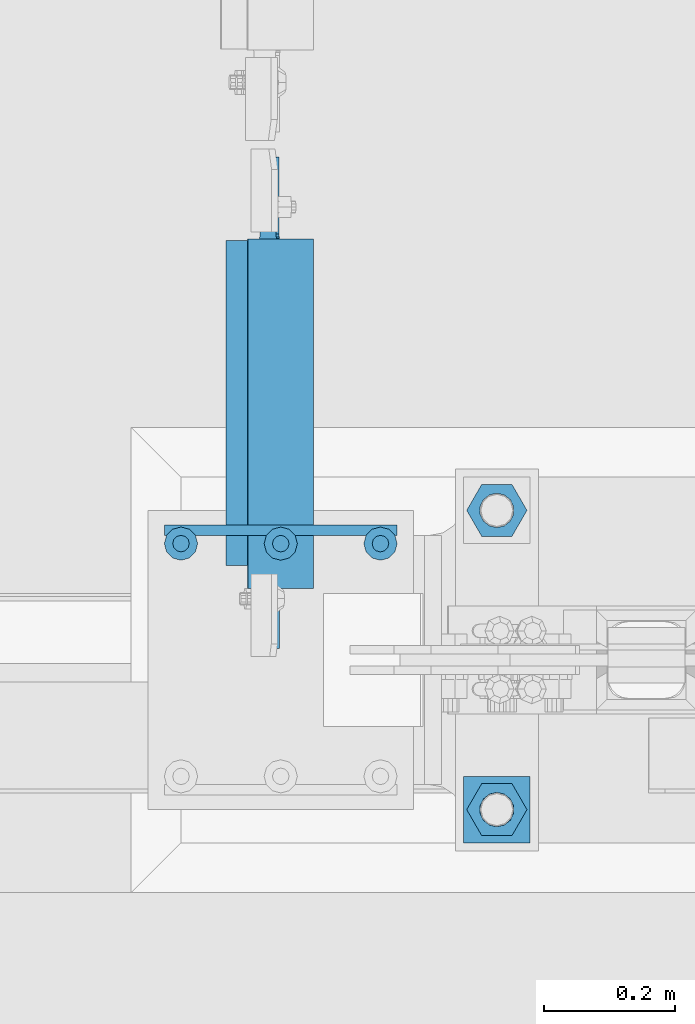
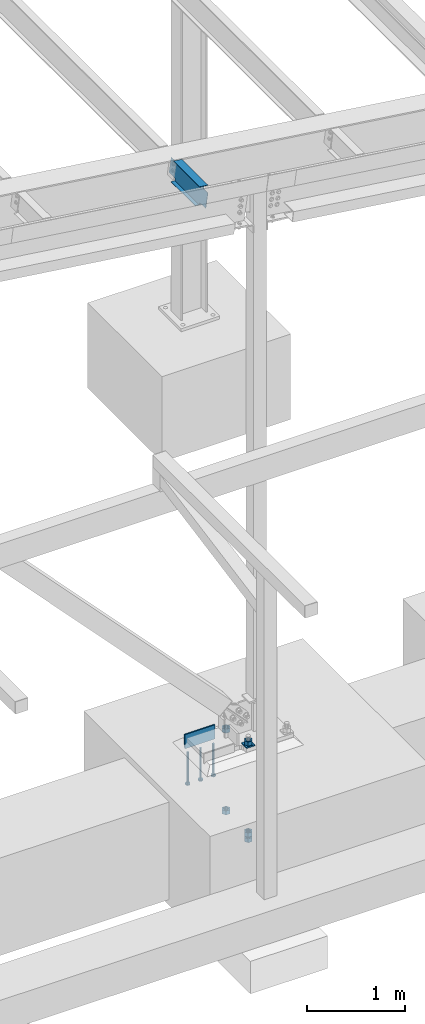
# One storey, part 850 of 1179: 11 beams, 4 elements without a shape of their own.
"""IFC2X3 building model written with IfcOpenShell, lengths in millimetres."""

from ifc_helpers import new_model, si_unit, frame, origin_with_axes, place, context, subcontext, project, spatial, faceted_brep, material, type_object, element, aggregate, save


model = new_model("IFC2X3")

# Units and contexts
model_context = context("Model", 3, precision=1e-05, world=origin_with_axes())
body_context = subcontext(model_context, "Body", "Model", "MODEL_VIEW")
ifc_project = project(units=[si_unit("LENGTHUNIT", "METRE", prefix="MILLI"), si_unit("AREAUNIT", "SQUARE_METRE"), si_unit("VOLUMEUNIT", "CUBIC_METRE"), si_unit("MASSUNIT", "GRAM", prefix="KILO"), si_unit("TIMEUNIT", "SECOND"), si_unit("PLANEANGLEUNIT", "RADIAN"), si_unit("SOLIDANGLEUNIT", "STERADIAN"), si_unit("THERMODYNAMICTEMPERATUREUNIT", "DEGREE_CELSIUS"), si_unit("LUMINOUSINTENSITYUNIT", "LUMEN")], contexts=[model_context])

# Site, building, storey
site_placement = place(None, origin_with_axes())
site = spatial("IfcSite", under=ifc_project, at=site_placement, CompositionType="ELEMENT")
building_placement = place(site_placement, origin_with_axes())
building = spatial("IfcBuilding", under=site, at=building_placement, Name="Undefined", CompositionType="ELEMENT")
storey_placement = place(building_placement, origin_with_axes())
storey = spatial("IfcBuildingStorey", under=building, at=storey_placement, Name="Undefined", CompositionType="ELEMENT", Elevation=0.0)

# Assembly, beam
assembly_1_placement = place(storey_placement, origin_with_axes())
assembly_1 = element("IfcElementAssembly", 1, at=assembly_1_placement, inside=storey, Name="BEAM", AssemblyPlace="NOTDEFINED", PredefinedType="RIGID_FRAME")
ifc_material_1 = material(Name="STEEL/A992")
beam_type_1 = type_object("IfcBeamType", Name="W10X12", PredefinedType="NOTDEFINED")
beam_1_placement = place(assembly_1_placement, frame((34349.418149051, 4648.2, 6554.19004945097), z_axis=(0.133813223953133, 0.0, 0.991006569652931), x_axis=(0.0, 1.0, 0.0)))
beam_1 = element("IfcBeam", 2, at=beam_1_placement, type_object=beam_type_1, material=ifc_material_1, Name="BEAM", ObjectType="W10X12", context=body_context, shape_type="Brep", body=[
    faceted_brep([(641.349999999998, -2.38124999986758, -120.650000000041), (641.349999999998, -50.7999999998792, -120.650000000054), (641.349999999998, -50.7999999998719, -125.412500000057), (641.349999999998, 50.8000000001484, -125.412500000028), (641.349999999998, 50.8000000001412, -120.650000000027), (641.349999999998, 2.38125000012951, -120.650000000038), (641.349999999998, 2.38125000012224, -106.362499801333), (641.349999999998, -2.38124999988213, -106.362499801329), (642.316729922585, 2.38125000011496, -101.502420283283), (642.316729922585, -2.38124999988213, -101.502420283279), (645.069743823064, 2.38125000011496, -97.3822438151255), (645.069743823064, -2.38124999988941, -97.3822438151219), (649.189920291217, 2.38125000010768, -94.6292299146444), (649.189920291217, -2.38124999989668, -94.6292299146407), (654.049999809263, 2.38125000010768, -93.6624999920532), (654.049999809263, -2.38124999989668, -93.6624999920496), (768.349999999998, -2.38124999988941, -93.6624999919513), (768.349999999998, 2.38125000010768, -93.6624999919441), (109.537500000001, 2.38124999985303, 120.650000000041), (109.537500000001, 50.7999999998647, 120.650000000056), (642.937499999997, 50.7999999998647, 120.650000000056), (642.937499999997, 2.38124999985303, 120.650000000041), (144.462500000001, -2.38124999988213, -106.362499807816), (144.462500000001, 2.38125000011496, -106.362499807819), (144.462500000001, 2.38125000012951, -120.650000000038), (144.462500000001, 50.8000000001412, -120.650000000027), (144.462500000001, 50.8000000001484, -125.412500000028), (144.462500000001, -50.7999999998719, -125.412500000057), (144.462500000001, -50.7999999998792, -120.650000000054), (144.462500000001, -2.38124999986758, -120.650000000041), (143.495770077414, -2.38124999988213, -101.502420289766), (143.495770077414, 2.38125000011496, -101.502420289768), (140.742756176935, -2.38124999988941, -97.3822438216066), (140.742756176935, 2.38125000011496, -97.3822438216102), (136.622579708782, -2.38124999989668, -94.6292299211254), (136.622579708782, 2.38125000010768, -94.6292299211291), (131.762500190736, -2.38124999988941, -93.6624999985379), (131.762500190736, 2.38125000010768, -93.6624999985397), (17.4624999999996, -2.38124999988941, -93.662499998647), (17.4624999999996, 2.38125000010768, -93.6624999986416), (17.4624999999996, -2.38125000011496, 93.6625000015429), (17.4624999999996, 2.38124999988941, 93.6625000015483), (96.8375001907361, -2.38125000011496, 93.662500001652), (96.8375001907361, 2.38124999988941, 93.6625000016502), (101.697579708782, -2.38125000011496, 94.6292299242414), (101.697579708782, 2.38124999987485, 94.6292299242377), (105.817756176935, -2.38125000011496, 97.3822438247225), (105.817756176935, 2.38124999988213, 97.3822438247189), (108.570770077414, -2.38125000012224, 101.50242029288), (108.570770077414, 2.38124999987485, 101.502420292876), (109.537500000001, -2.38125000012951, 106.36249981093), (109.537500000001, 2.38124999986758, 106.362499810928), (109.537500000001, -50.800000000163, 125.412500000028), (109.537500000001, 50.7999999998574, 125.412500000059), (109.537500000001, -2.38125000014406, 120.650000000041), (109.537500000001, -50.8000000001557, 120.650000000027), (642.937499999997, -2.38125000014406, 120.650000000041), (642.937499999997, -50.8000000001557, 120.650000000027), (642.937499999997, -50.800000000163, 125.412500000028), (642.937499999997, 50.7999999998574, 125.412500000059), (642.937499999997, -2.38125000012224, 100.012499817411), (642.937499999997, 2.38124999987485, 100.012499817409), (643.904229922585, -2.38125000012224, 95.1524202993623), (643.904229922585, 2.38124999988213, 95.1524202993587), (646.657243823063, -2.38125000011496, 91.0322438312032), (646.657243823063, 2.38124999988941, 91.0322438311996), (650.777420291217, -2.38125000010768, 88.2792299307239), (650.777420291217, 2.38124999988941, 88.2792299307202), (655.637499809262, -2.38125000010768, 87.3125000081345), (655.637499809262, 2.38124999988941, 87.3125000081309), (768.349999999998, -2.38125000010768, 87.3125000082346), (768.349999999998, 2.38124999988941, 87.31250000824)], [[[0, 1, 2, 3, 4, 5, 6, 7]], [[7, 6, 8, 9]], [[9, 8, 10, 11]], [[11, 10, 12, 13]], [[13, 12, 14, 15]], [[16, 15, 14, 17]], [[18, 19, 20, 21]], [[22, 23, 24, 25, 26, 27, 28, 29]], [[30, 31, 23, 22]], [[32, 33, 31, 30]], [[34, 35, 33, 32]], [[36, 37, 35, 34]], [[38, 39, 37, 36]], [[40, 41, 39, 38]], [[42, 43, 41, 40]], [[44, 45, 43, 42]], [[46, 47, 45, 44]], [[48, 49, 47, 46]], [[50, 51, 49, 48]], [[52, 53, 19, 18, 51, 50, 54, 55]], [[55, 54, 56, 57]], [[52, 55, 57, 58]], [[53, 52, 58, 59]], [[19, 53, 59, 20]], [[58, 57, 56, 60, 61, 21, 20, 59]], [[62, 63, 61, 60]], [[64, 65, 63, 62]], [[66, 67, 65, 64]], [[68, 69, 67, 66]], [[70, 71, 69, 68]], [[71, 70, 16, 17]], [[12, 10, 8, 6, 5, 24, 23, 31, 33, 35, 37, 39, 41, 43, 45, 47, 49, 51, 18, 21, 61, 63, 65, 67, 69, 71, 17, 14]], [[25, 24, 5, 4]], [[26, 25, 4, 3]], [[27, 26, 3, 2]], [[28, 27, 2, 1]], [[29, 28, 1, 0]], [[70, 68, 66, 64, 62, 60, 56, 54, 50, 48, 46, 44, 42, 40, 38, 36, 34, 32, 30, 22, 29, 0, 7, 9, 11, 13, 15, 16]]]),
])
aggregate(assembly_1, [beam_1])

# Assembly, beams
assembly_2_placement = place(storey_placement, origin_with_axes())
assembly_2 = element("IfcElementAssembly", 3, at=assembly_2_placement, inside=storey, Name="TEMPLATE", AssemblyPlace="NOTDEFINED", PredefinedType="RIGID_FRAME")
ifc_material_2 = material(Name="STEEL/A36")
beam_type_2 = type_object("IfcBeamType", PredefinedType="NOTDEFINED")
beam_2_placement = place(assembly_2_placement, frame((34747.1989938965, 4419.60000610352, -220.662499999998), z_axis=(0.0, -1.0, 0.0), x_axis=(-1.0, 0.0, 0.0)))
beam_2 = element("IfcBeam", 4, at=beam_2_placement, type_object=beam_type_2, material=ifc_material_2, Name="SQ WASHER", context=body_context, shape_type="Brep", body=[
    faceted_brep([(0.0, 7.9375, -50.8000000000002), (0.0, 7.9375, 50.8000000000002), (101.598992919513, 7.9375, 50.8000000000002), (101.598992919513, 7.9375, -50.8000000000002), (0.0, -7.9375, 50.8000000000002), (101.598992919513, -7.9375, 50.8000000000002), (0.0, -7.9375, -50.8000000000002), (101.598992919513, -7.9375, -50.8000000000002)], [[[0, 1, 2, 3]], [[1, 4, 5, 2]], [[4, 6, 7, 5]], [[6, 0, 3, 7]], [[5, 7, 3, 2]], [[6, 4, 1, 0]]]),
])
beam_type_3 = type_object("IfcBeamType", Name="2_HEAVY_HEX_NUT", PredefinedType="NOTDEFINED")
beam_3_placement = place(assembly_2_placement, frame((34696.400012207, 4876.8, -279.4), z_axis=(0.0, -1.0, 0.0), x_axis=(0.0, 0.0, -1.0)))
beam_3 = element("IfcBeam", 5, at=beam_3_placement, type_object=beam_type_3, material=ifc_material_2, Name="NUT", ObjectType="2_HEAVY_HEX_NUT", context=body_context, shape_type="Brep", body=[
    faceted_brep([(0.0, -46.0369987487793, 9.09494701772928e-13), (0.0, -23.0184993743896, -39.869213104248), (50.7999999999993, -23.0184993743896, -39.869213104248), (50.7999999999993, -46.0369987487793, 9.09494701772928e-13), (0.0, 23.0184993743896, -39.869213104248), (50.7999999999993, 23.0184993743896, -39.869213104248), (0.0, 46.0369987487793, -9.09494701772928e-13), (50.7999999999993, 46.0369987487793, -9.09494701772928e-13), (0.0, 23.0184993743896, 39.869213104248), (50.7999999999993, 23.0184993743896, 39.869213104248), (0.0, -23.0184993743896, 39.869213104248), (50.7999999999993, -23.0184993743896, 39.869213104248), (0.0, 0.0, 26.1940002441406), (0.0, 11.3650617044477, 23.5999013092769), (50.7999999999993, 11.3650617044477, 23.5999013092769), (50.7999999999993, 0.0, 26.1940002441406), (0.0, 20.4791109456419, 16.3316083006703), (50.7999999999993, 20.4791109456419, 16.3316083006703), (0.0, 25.5370200498364, 5.82867859874477), (50.7999999999993, 25.5370200498364, 5.82867859874477), (0.0, 25.5370200498364, -5.82867859874477), (50.7999999999993, 25.5370200498364, -5.82867859874477), (0.0, 20.4791109456419, -16.3316083006703), (50.7999999999993, 20.4791109456419, -16.3316083006703), (0.0, 11.365061704455, -23.5999013092769), (50.7999999999993, 11.365061704455, -23.5999013092769), (0.0, 0.0, -26.1940002441406), (50.7999999999993, 0.0, -26.1940002441406), (0.0, -11.3650617044477, -23.5999013092769), (50.7999999999993, -11.3650617044477, -23.5999013092769), (0.0, -20.4791109456419, -16.3316083006703), (50.7999999999993, -20.4791109456419, -16.3316083006703), (0.0, -25.5370200498364, -5.82867859874477), (50.7999999999993, -25.5370200498364, -5.82867859874477), (0.0, -25.5370200498364, 5.82867859874477), (50.7999999999993, -25.5370200498364, 5.82867859874477), (0.0, -20.4791109456419, 16.3316083006703), (50.7999999999993, -20.4791109456419, 16.3316083006703), (0.0, -11.365061704455, 23.5999013092769), (50.7999999999993, -11.365061704455, 23.5999013092769)], [[[0, 1, 2, 3]], [[1, 4, 5, 2]], [[4, 6, 7, 5]], [[6, 8, 9, 7]], [[8, 10, 11, 9]], [[10, 0, 3, 11]], [[12, 13, 14, 15]], [[13, 16, 17, 14]], [[16, 18, 19, 17]], [[18, 20, 21, 19]], [[20, 22, 23, 21]], [[22, 24, 25, 23]], [[24, 26, 27, 25]], [[26, 28, 29, 27]], [[28, 30, 31, 29]], [[30, 32, 33, 31]], [[32, 34, 35, 33]], [[34, 36, 37, 35]], [[36, 38, 39, 37]], [[38, 12, 15, 39]], [[5, 7, 9, 11, 3, 2], [17, 19, 21, 23, 25, 27, 29, 31, 33, 35, 37, 39, 15, 14]], [[10, 8, 6, 4, 1, 0], [38, 36, 34, 32, 30, 28, 26, 24, 22, 20, 18, 16, 13, 12]]]),
])
beam_4_placement = place(assembly_2_placement, frame((34696.4, 4876.8, -1301.75), z_axis=(0.0, -1.0, 0.0), x_axis=(0.0, 0.0, -1.0)))
beam_4 = element("IfcBeam", 6, at=beam_4_placement, type_object=beam_type_3, material=ifc_material_2, Name="NUT", ObjectType="2_HEAVY_HEX_NUT", context=body_context, shape_type="Brep", body=[
    faceted_brep([(0.0, -46.0369987487793, 9.09494701772928e-13), (0.0, -23.0184993743896, -39.869213104248), (50.7999999999993, -23.0184993743896, -39.869213104248), (50.7999999999993, -46.0369987487793, 9.09494701772928e-13), (0.0, 23.0184993743896, -39.869213104248), (50.7999999999993, 23.0184993743896, -39.869213104248), (0.0, 46.0369987487793, -9.09494701772928e-13), (50.7999999999993, 46.0369987487793, -9.09494701772928e-13), (0.0, 23.0184993743896, 39.869213104248), (50.7999999999993, 23.0184993743896, 39.869213104248), (0.0, -23.0184993743896, 39.869213104248), (50.7999999999993, -23.0184993743896, 39.869213104248), (0.0, 0.0, 26.1940002441406), (0.0, 11.3650617044477, 23.5999013092769), (50.7999999999993, 11.3650617044477, 23.5999013092769), (50.7999999999993, 0.0, 26.1940002441406), (0.0, 20.4791109456419, 16.3316083006703), (50.7999999999993, 20.4791109456419, 16.3316083006703), (0.0, 25.5370200498364, 5.82867859874477), (50.7999999999993, 25.5370200498364, 5.82867859874477), (0.0, 25.5370200498364, -5.82867859874477), (50.7999999999993, 25.5370200498364, -5.82867859874477), (0.0, 20.4791109456419, -16.3316083006703), (50.7999999999993, 20.4791109456419, -16.3316083006703), (0.0, 11.365061704455, -23.5999013092769), (50.7999999999993, 11.365061704455, -23.5999013092769), (0.0, 0.0, -26.1940002441406), (50.7999999999993, 0.0, -26.1940002441406), (0.0, -11.3650617044477, -23.5999013092769), (50.7999999999993, -11.3650617044477, -23.5999013092769), (0.0, -20.4791109456419, -16.3316083006703), (50.7999999999993, -20.4791109456419, -16.3316083006703), (0.0, -25.5370200498364, -5.82867859874477), (50.7999999999993, -25.5370200498364, -5.82867859874477), (0.0, -25.5370200498364, 5.82867859874477), (50.7999999999993, -25.5370200498364, 5.82867859874477), (0.0, -20.4791109456419, 16.3316083006703), (50.7999999999993, -20.4791109456419, 16.3316083006703), (0.0, -11.365061704455, 23.5999013092769), (50.7999999999993, -11.365061704455, 23.5999013092769)], [[[0, 1, 2, 3]], [[1, 4, 5, 2]], [[4, 6, 7, 5]], [[6, 8, 9, 7]], [[8, 10, 11, 9]], [[10, 0, 3, 11]], [[12, 13, 14, 15]], [[13, 16, 17, 14]], [[16, 18, 19, 17]], [[18, 20, 21, 19]], [[20, 22, 23, 21]], [[22, 24, 25, 23]], [[24, 26, 27, 25]], [[26, 28, 29, 27]], [[28, 30, 31, 29]], [[30, 32, 33, 31]], [[32, 34, 35, 33]], [[34, 36, 37, 35]], [[36, 38, 39, 37]], [[38, 12, 15, 39]], [[5, 7, 9, 11, 3, 2], [17, 19, 21, 23, 25, 27, 29, 31, 33, 35, 37, 39, 15, 14]], [[10, 8, 6, 4, 1, 0], [38, 36, 34, 32, 30, 28, 26, 24, 22, 20, 18, 16, 13, 12]]]),
])
beam_5_placement = place(assembly_2_placement, frame((34696.4, 4419.6, -1301.75), z_axis=(0.0, -1.0, 0.0), x_axis=(0.0, 0.0, -1.0)))
beam_5 = element("IfcBeam", 7, at=beam_5_placement, type_object=beam_type_3, material=ifc_material_2, Name="NUT", ObjectType="2_HEAVY_HEX_NUT", context=body_context, shape_type="Brep", body=[
    faceted_brep([(0.0, -46.0369987487793, 9.09494701772928e-13), (0.0, -23.0184993743896, -39.869213104248), (50.7999999999993, -23.0184993743896, -39.869213104248), (50.7999999999993, -46.0369987487793, 9.09494701772928e-13), (0.0, 23.0184993743896, -39.869213104248), (50.7999999999993, 23.0184993743896, -39.869213104248), (0.0, 46.0369987487793, -9.09494701772928e-13), (50.7999999999993, 46.0369987487793, -9.09494701772928e-13), (0.0, 23.0184993743896, 39.869213104248), (50.7999999999993, 23.0184993743896, 39.869213104248), (0.0, -23.0184993743896, 39.869213104248), (50.7999999999993, -23.0184993743896, 39.869213104248), (0.0, 0.0, 26.1940002441406), (0.0, 11.3650617044477, 23.5999013092769), (50.7999999999993, 11.3650617044477, 23.5999013092769), (50.7999999999993, 0.0, 26.1940002441406), (0.0, 20.4791109456419, 16.3316083006703), (50.7999999999993, 20.4791109456419, 16.3316083006703), (0.0, 25.5370200498364, 5.82867859874477), (50.7999999999993, 25.5370200498364, 5.82867859874477), (0.0, 25.5370200498364, -5.82867859874477), (50.7999999999993, 25.5370200498364, -5.82867859874477), (0.0, 20.4791109456419, -16.3316083006703), (50.7999999999993, 20.4791109456419, -16.3316083006703), (0.0, 11.365061704455, -23.5999013092769), (50.7999999999993, 11.365061704455, -23.5999013092769), (0.0, 0.0, -26.1940002441406), (50.7999999999993, 0.0, -26.1940002441406), (0.0, -11.3650617044477, -23.5999013092769), (50.7999999999993, -11.3650617044477, -23.5999013092769), (0.0, -20.4791109456419, -16.3316083006703), (50.7999999999993, -20.4791109456419, -16.3316083006703), (0.0, -25.5370200498364, -5.82867859874477), (50.7999999999993, -25.5370200498364, -5.82867859874477), (0.0, -25.5370200498364, 5.82867859874477), (50.7999999999993, -25.5370200498364, 5.82867859874477), (0.0, -20.4791109456419, 16.3316083006703), (50.7999999999993, -20.4791109456419, 16.3316083006703), (0.0, -11.365061704455, 23.5999013092769), (50.7999999999993, -11.365061704455, 23.5999013092769)], [[[0, 1, 2, 3]], [[1, 4, 5, 2]], [[4, 6, 7, 5]], [[6, 8, 9, 7]], [[8, 10, 11, 9]], [[10, 0, 3, 11]], [[12, 13, 14, 15]], [[13, 16, 17, 14]], [[16, 18, 19, 17]], [[18, 20, 21, 19]], [[20, 22, 23, 21]], [[22, 24, 25, 23]], [[24, 26, 27, 25]], [[26, 28, 29, 27]], [[28, 30, 31, 29]], [[30, 32, 33, 31]], [[32, 34, 35, 33]], [[34, 36, 37, 35]], [[36, 38, 39, 37]], [[38, 12, 15, 39]], [[5, 7, 9, 11, 3, 2], [17, 19, 21, 23, 25, 27, 29, 31, 33, 35, 37, 39, 15, 14]], [[10, 8, 6, 4, 1, 0], [38, 36, 34, 32, 30, 28, 26, 24, 22, 20, 18, 16, 13, 12]]]),
])
beam_6_placement = place(assembly_2_placement, frame((34696.4, 4419.6, -1371.59999923706), z_axis=(0.0, -1.0, 0.0), x_axis=(0.0, 0.0, -1.0)))
beam_6 = element("IfcBeam", 8, at=beam_6_placement, type_object=beam_type_3, material=ifc_material_2, Name="NUT", ObjectType="2_HEAVY_HEX_NUT", context=body_context, shape_type="Brep", body=[
    faceted_brep([(0.0, -46.0369987487793, 9.09494701772928e-13), (0.0, -23.0184993743896, -39.869213104248), (50.7999999999993, -23.0184993743896, -39.869213104248), (50.7999999999993, -46.0369987487793, 9.09494701772928e-13), (0.0, 23.0184993743896, -39.869213104248), (50.7999999999993, 23.0184993743896, -39.869213104248), (0.0, 46.0369987487793, -9.09494701772928e-13), (50.7999999999993, 46.0369987487793, -9.09494701772928e-13), (0.0, 23.0184993743896, 39.869213104248), (50.7999999999993, 23.0184993743896, 39.869213104248), (0.0, -23.0184993743896, 39.869213104248), (50.7999999999993, -23.0184993743896, 39.869213104248), (0.0, 0.0, 26.1940002441406), (0.0, 11.3650617044477, 23.5999013092769), (50.7999999999993, 11.3650617044477, 23.5999013092769), (50.7999999999993, 0.0, 26.1940002441406), (0.0, 20.4791109456419, 16.3316083006703), (50.7999999999993, 20.4791109456419, 16.3316083006703), (0.0, 25.5370200498364, 5.82867859874477), (50.7999999999993, 25.5370200498364, 5.82867859874477), (0.0, 25.5370200498364, -5.82867859874477), (50.7999999999993, 25.5370200498364, -5.82867859874477), (0.0, 20.4791109456419, -16.3316083006703), (50.7999999999993, 20.4791109456419, -16.3316083006703), (0.0, 11.365061704455, -23.5999013092769), (50.7999999999993, 11.365061704455, -23.5999013092769), (0.0, 0.0, -26.1940002441406), (50.7999999999993, 0.0, -26.1940002441406), (0.0, -11.3650617044477, -23.5999013092769), (50.7999999999993, -11.3650617044477, -23.5999013092769), (0.0, -20.4791109456419, -16.3316083006703), (50.7999999999993, -20.4791109456419, -16.3316083006703), (0.0, -25.5370200498364, -5.82867859874477), (50.7999999999993, -25.5370200498364, -5.82867859874477), (0.0, -25.5370200498364, 5.82867859874477), (50.7999999999993, -25.5370200498364, 5.82867859874477), (0.0, -20.4791109456419, 16.3316083006703), (50.7999999999993, -20.4791109456419, 16.3316083006703), (0.0, -11.365061704455, 23.5999013092769), (50.7999999999993, -11.365061704455, 23.5999013092769)], [[[0, 1, 2, 3]], [[1, 4, 5, 2]], [[4, 6, 7, 5]], [[6, 8, 9, 7]], [[8, 10, 11, 9]], [[10, 0, 3, 11]], [[12, 13, 14, 15]], [[13, 16, 17, 14]], [[16, 18, 19, 17]], [[18, 20, 21, 19]], [[20, 22, 23, 21]], [[22, 24, 25, 23]], [[24, 26, 27, 25]], [[26, 28, 29, 27]], [[28, 30, 31, 29]], [[30, 32, 33, 31]], [[32, 34, 35, 33]], [[34, 36, 37, 35]], [[36, 38, 39, 37]], [[38, 12, 15, 39]], [[5, 7, 9, 11, 3, 2], [17, 19, 21, 23, 25, 27, 29, 31, 33, 35, 37, 39, 15, 14]], [[10, 8, 6, 4, 1, 0], [38, 36, 34, 32, 30, 28, 26, 24, 22, 20, 18, 16, 13, 12]]]),
])
beam_7_placement = place(assembly_2_placement, frame((34696.4, 4419.6, -161.924999999999), z_axis=(0.0, -1.0, 0.0), x_axis=(0.0, 0.0, -1.0)))
beam_7 = element("IfcBeam", 9, at=beam_7_placement, type_object=beam_type_3, material=ifc_material_2, Name="NUT", ObjectType="2_HEAVY_HEX_NUT", context=body_context, shape_type="Brep", body=[
    faceted_brep([(0.0, -46.0369987487793, 9.09494701772928e-13), (0.0, -23.0184993743896, -39.869213104248), (50.7999999999993, -23.0184993743896, -39.869213104248), (50.7999999999993, -46.0369987487793, 9.09494701772928e-13), (0.0, 23.0184993743896, -39.869213104248), (50.7999999999993, 23.0184993743896, -39.869213104248), (0.0, 46.0369987487793, -9.09494701772928e-13), (50.7999999999993, 46.0369987487793, -9.09494701772928e-13), (0.0, 23.0184993743896, 39.869213104248), (50.7999999999993, 23.0184993743896, 39.869213104248), (0.0, -23.0184993743896, 39.869213104248), (50.7999999999993, -23.0184993743896, 39.869213104248), (0.0, 0.0, 26.1940002441406), (0.0, 11.3650617044477, 23.5999013092769), (50.7999999999993, 11.3650617044477, 23.5999013092769), (50.7999999999993, 0.0, 26.1940002441406), (0.0, 20.4791109456419, 16.3316083006703), (50.7999999999993, 20.4791109456419, 16.3316083006703), (0.0, 25.5370200498364, 5.82867859874477), (50.7999999999993, 25.5370200498364, 5.82867859874477), (0.0, 25.5370200498364, -5.82867859874477), (50.7999999999993, 25.5370200498364, -5.82867859874477), (0.0, 20.4791109456419, -16.3316083006703), (50.7999999999993, 20.4791109456419, -16.3316083006703), (0.0, 11.365061704455, -23.5999013092769), (50.7999999999993, 11.365061704455, -23.5999013092769), (0.0, 0.0, -26.1940002441406), (50.7999999999993, 0.0, -26.1940002441406), (0.0, -11.3650617044477, -23.5999013092769), (50.7999999999993, -11.3650617044477, -23.5999013092769), (0.0, -20.4791109456419, -16.3316083006703), (50.7999999999993, -20.4791109456419, -16.3316083006703), (0.0, -25.5370200498364, -5.82867859874477), (50.7999999999993, -25.5370200498364, -5.82867859874477), (0.0, -25.5370200498364, 5.82867859874477), (50.7999999999993, -25.5370200498364, 5.82867859874477), (0.0, -20.4791109456419, 16.3316083006703), (50.7999999999993, -20.4791109456419, 16.3316083006703), (0.0, -11.365061704455, 23.5999013092769), (50.7999999999993, -11.365061704455, 23.5999013092769)], [[[0, 1, 2, 3]], [[1, 4, 5, 2]], [[4, 6, 7, 5]], [[6, 8, 9, 7]], [[8, 10, 11, 9]], [[10, 0, 3, 11]], [[12, 13, 14, 15]], [[13, 16, 17, 14]], [[16, 18, 19, 17]], [[18, 20, 21, 19]], [[20, 22, 23, 21]], [[22, 24, 25, 23]], [[24, 26, 27, 25]], [[26, 28, 29, 27]], [[28, 30, 31, 29]], [[30, 32, 33, 31]], [[32, 34, 35, 33]], [[34, 36, 37, 35]], [[36, 38, 39, 37]], [[38, 12, 15, 39]], [[5, 7, 9, 11, 3, 2], [17, 19, 21, 23, 25, 27, 29, 31, 33, 35, 37, 39, 15, 14]], [[10, 8, 6, 4, 1, 0], [38, 36, 34, 32, 30, 28, 26, 24, 22, 20, 18, 16, 13, 12]]]),
])
aggregate(assembly_2, [beam_3, beam_4, beam_5, beam_6, beam_2, beam_7])

# Assembly, beam
assembly_3_placement = place(storey_placement, origin_with_axes())
assembly_3 = element("IfcElementAssembly", 10, at=assembly_3_placement, inside=storey, Name="PLATE", AssemblyPlace="NOTDEFINED", PredefinedType="RIGID_FRAME")
ifc_material_3 = material(Name="STEEL/A572-GR.50")
beam_type_4 = type_object("IfcBeamType", PredefinedType="NOTDEFINED")
beam_8_placement = place(assembly_3_placement, frame((34543.9999993009, 4846.63750152631, -266.7), z_axis=(0.0, 0.0, 1.0), x_axis=(-1.0, 0.0, 0.0)))
beam_8 = element("IfcBeam", 11, at=beam_8_placement, type_object=beam_type_4, material=ifc_material_3, Name="PLATE", context=body_context, shape_type="Brep", body=[
    faceted_brep([(355.599999999999, 7.9375, -88.9), (355.599999999999, -7.9375, -73.025), (0.0, -7.9375, -73.025), (0.0, 7.9375, -88.9), (0.0, 7.9375, 88.9), (355.599999999999, 7.9375, 88.9), (0.0, -7.9375, 88.9), (355.599999999999, -7.9375, 88.9)], [[[0, 1, 2, 3]], [[3, 4, 5, 0]], [[4, 6, 7, 5]], [[7, 6, 2, 1]], [[5, 7, 1, 0]], [[6, 4, 3, 2]]]),
])
aggregate(assembly_3, [beam_8])

# Assembly, beams
assembly_4_placement = place(storey_placement, origin_with_axes())
assembly_4 = element("IfcElementAssembly", 12, at=assembly_4_placement, inside=storey, Name="EMBED_PLATE", AssemblyPlace="NOTDEFINED", PredefinedType="RIGID_FRAME")
ifc_material_4 = material(Name="STEEL/A108")
beam_type_5 = type_object("IfcBeamType", Name="STUD_1-DIA", PredefinedType="NOTDEFINED")
beam_9_placement = place(assembly_4_placement, frame((34518.6, 4826.0, -393.7), z_axis=(-1.0, 0.0, 0.0), x_axis=(0.0, 0.0, -1.0)))
beam_9 = element("IfcBeam", 13, at=beam_9_placement, type_object=beam_type_5, material=ifc_material_4, Name="STUD", ObjectType="STUD_1-DIA", context=body_context, shape_type="Brep", body=[
    faceted_brep([(0.0, -12.7, 0.0), (0.0, -11.0, -6.34999990463257), (382.016, -11.0, -6.34999990463257), (382.016, -12.6999998092651, 0.0), (0.0, -6.34999990463257, -11.0), (382.016, -6.34999990463257, -11.0), (0.0, 0.0, -12.6999998092651), (382.016, 0.0, -12.6999998092651), (0.0, 6.34999990463257, -11.0), (382.016, 6.34999990463257, -11.0), (0.0, 11.0, -6.34999990463257), (382.016, 11.0, -6.34999990463257), (0.0, 12.7, 0.0), (382.016, 12.6999998092651, 0.0), (0.0, 11.0, 6.34999990463257), (382.016, 11.0, 6.34999990463257), (0.0, 6.34999990463257, 11.0), (382.016, 6.34999990463257, 11.0), (0.0, 0.0, 12.6999998092651), (382.016, 0.0, 12.6999998092651), (0.0, -6.34999990463257, 11.0), (382.016, -6.34999990463257, 11.0), (0.0, -11.0, 6.34999990463257), (382.016, -11.0, 6.34999990463257), (386.08, -22.0, -12.6999998092651), (386.08, -25.3999996185303, 0.0), (386.08, -12.6999998092651, -22.0), (386.08, 0.0, -25.3999996185303), (386.08, 12.6999998092651, -22.0), (386.08, 22.0, -12.6999998092651), (386.08, 25.3999996185303, 0.0), (386.08, 22.0, 12.6999998092651), (386.08, 12.6999998092651, 22.0), (386.08, 0.0, 25.3999996185303), (386.08, -12.6999998092651, 22.0), (386.08, -22.0, 12.6999998092651), (406.4, -22.0, -12.6999998092651), (406.4, -25.3999996185303, 0.0), (406.4, -12.6999998092651, -22.0), (406.4, 0.0, -25.3999996185303), (406.4, 12.6999998092651, -22.0), (406.4, 22.0, -12.6999998092651), (406.4, 25.3999996185303, 0.0), (406.4, 22.0, 12.6999998092651), (406.4, 12.6999998092651, 22.0), (406.4, 0.0, 25.3999996185303), (406.4, -12.6999998092651, 22.0), (406.4, -22.0, 12.6999998092651)], [[[0, 1, 2, 3]], [[1, 4, 5, 2]], [[4, 6, 7, 5]], [[6, 8, 9, 7]], [[8, 10, 11, 9]], [[10, 12, 13, 11]], [[12, 14, 15, 13]], [[14, 16, 17, 15]], [[16, 18, 19, 17]], [[18, 20, 21, 19]], [[20, 22, 23, 21]], [[22, 0, 3, 23]], [[22, 20, 18, 16, 14, 12, 10, 8, 6, 4, 1, 0]], [[3, 2, 24, 25]], [[2, 5, 26, 24]], [[5, 7, 27, 26]], [[7, 9, 28, 27]], [[9, 11, 29, 28]], [[11, 13, 30, 29]], [[13, 15, 31, 30]], [[15, 17, 32, 31]], [[17, 19, 33, 32]], [[19, 21, 34, 33]], [[21, 23, 35, 34]], [[23, 3, 25, 35]], [[25, 24, 36, 37]], [[24, 26, 38, 36]], [[26, 27, 39, 38]], [[27, 28, 40, 39]], [[28, 29, 41, 40]], [[29, 30, 42, 41]], [[30, 31, 43, 42]], [[31, 32, 44, 43]], [[32, 33, 45, 44]], [[33, 34, 46, 45]], [[34, 35, 47, 46]], [[35, 25, 37, 47]], [[38, 39, 40, 41, 42, 43, 44, 45, 46, 47, 37, 36]]]),
])
beam_10_placement = place(assembly_4_placement, frame((34213.8, 4826.0, -393.7), z_axis=(-1.0, 0.0, 0.0), x_axis=(0.0, 0.0, -1.0)))
beam_10 = element("IfcBeam", 14, at=beam_10_placement, type_object=beam_type_5, material=ifc_material_4, Name="STUD", ObjectType="STUD_1-DIA", context=body_context, shape_type="Brep", body=[
    faceted_brep([(0.0, -12.7, 0.0), (0.0, -11.0, -6.34999990463257), (382.016, -11.0, -6.34999990463257), (382.016, -12.6999998092651, 0.0), (0.0, -6.34999990463257, -11.0), (382.016, -6.34999990463257, -11.0), (0.0, 0.0, -12.6999998092651), (382.016, 0.0, -12.6999998092651), (0.0, 6.34999990463257, -11.0), (382.016, 6.34999990463257, -11.0), (0.0, 11.0, -6.34999990463257), (382.016, 11.0, -6.34999990463257), (0.0, 12.7, 0.0), (382.016, 12.6999998092651, 0.0), (0.0, 11.0, 6.34999990463257), (382.016, 11.0, 6.34999990463257), (0.0, 6.34999990463257, 11.0), (382.016, 6.34999990463257, 11.0), (0.0, 0.0, 12.6999998092651), (382.016, 0.0, 12.6999998092651), (0.0, -6.34999990463257, 11.0), (382.016, -6.34999990463257, 11.0), (0.0, -11.0, 6.34999990463257), (382.016, -11.0, 6.34999990463257), (386.08, -22.0, -12.6999998092651), (386.08, -25.3999996185303, 0.0), (386.08, -12.6999998092651, -22.0), (386.08, 0.0, -25.3999996185303), (386.08, 12.6999998092651, -22.0), (386.08, 22.0, -12.6999998092651), (386.08, 25.3999996185303, 0.0), (386.08, 22.0, 12.6999998092651), (386.08, 12.6999998092651, 22.0), (386.08, 0.0, 25.3999996185303), (386.08, -12.6999998092651, 22.0), (386.08, -22.0, 12.6999998092651), (406.4, -22.0, -12.6999998092651), (406.4, -25.3999996185303, 0.0), (406.4, -12.6999998092651, -22.0), (406.4, 0.0, -25.3999996185303), (406.4, 12.6999998092651, -22.0), (406.4, 22.0, -12.6999998092651), (406.4, 25.3999996185303, 0.0), (406.4, 22.0, 12.6999998092651), (406.4, 12.6999998092651, 22.0), (406.4, 0.0, 25.3999996185303), (406.4, -12.6999998092651, 22.0), (406.4, -22.0, 12.6999998092651)], [[[0, 1, 2, 3]], [[1, 4, 5, 2]], [[4, 6, 7, 5]], [[6, 8, 9, 7]], [[8, 10, 11, 9]], [[10, 12, 13, 11]], [[12, 14, 15, 13]], [[14, 16, 17, 15]], [[16, 18, 19, 17]], [[18, 20, 21, 19]], [[20, 22, 23, 21]], [[22, 0, 3, 23]], [[22, 20, 18, 16, 14, 12, 10, 8, 6, 4, 1, 0]], [[3, 2, 24, 25]], [[2, 5, 26, 24]], [[5, 7, 27, 26]], [[7, 9, 28, 27]], [[9, 11, 29, 28]], [[11, 13, 30, 29]], [[13, 15, 31, 30]], [[15, 17, 32, 31]], [[17, 19, 33, 32]], [[19, 21, 34, 33]], [[21, 23, 35, 34]], [[23, 3, 25, 35]], [[25, 24, 36, 37]], [[24, 26, 38, 36]], [[26, 27, 39, 38]], [[27, 28, 40, 39]], [[28, 29, 41, 40]], [[29, 30, 42, 41]], [[30, 31, 43, 42]], [[31, 32, 44, 43]], [[32, 33, 45, 44]], [[33, 34, 46, 45]], [[34, 35, 47, 46]], [[35, 25, 37, 47]], [[38, 39, 40, 41, 42, 43, 44, 45, 46, 47, 37, 36]]]),
])
beam_11_placement = place(assembly_4_placement, frame((34366.2, 4826.0, -393.7), z_axis=(-1.0, 0.0, 0.0), x_axis=(0.0, 0.0, -1.0)))
beam_11 = element("IfcBeam", 15, at=beam_11_placement, type_object=beam_type_5, material=ifc_material_4, Name="STUD", ObjectType="STUD_1-DIA", context=body_context, shape_type="Brep", body=[
    faceted_brep([(0.0, -12.7, 0.0), (0.0, -11.0, -6.34999990463257), (382.016, -11.0, -6.34999990463257), (382.016, -12.6999998092651, 0.0), (0.0, -6.34999990463257, -11.0), (382.016, -6.34999990463257, -11.0), (0.0, 0.0, -12.6999998092651), (382.016, 0.0, -12.6999998092651), (0.0, 6.34999990463257, -11.0), (382.016, 6.34999990463257, -11.0), (0.0, 11.0, -6.34999990463257), (382.016, 11.0, -6.34999990463257), (0.0, 12.7, 0.0), (382.016, 12.6999998092651, 0.0), (0.0, 11.0, 6.34999990463257), (382.016, 11.0, 6.34999990463257), (0.0, 6.34999990463257, 11.0), (382.016, 6.34999990463257, 11.0), (0.0, 0.0, 12.6999998092651), (382.016, 0.0, 12.6999998092651), (0.0, -6.34999990463257, 11.0), (382.016, -6.34999990463257, 11.0), (0.0, -11.0, 6.34999990463257), (382.016, -11.0, 6.34999990463257), (386.08, -22.0, -12.6999998092651), (386.08, -25.3999996185303, 0.0), (386.08, -12.6999998092651, -22.0), (386.08, 0.0, -25.3999996185303), (386.08, 12.6999998092651, -22.0), (386.08, 22.0, -12.6999998092651), (386.08, 25.3999996185303, 0.0), (386.08, 22.0, 12.6999998092651), (386.08, 12.6999998092651, 22.0), (386.08, 0.0, 25.3999996185303), (386.08, -12.6999998092651, 22.0), (386.08, -22.0, 12.6999998092651), (406.4, -22.0, -12.6999998092651), (406.4, -25.3999996185303, 0.0), (406.4, -12.6999998092651, -22.0), (406.4, 0.0, -25.3999996185303), (406.4, 12.6999998092651, -22.0), (406.4, 22.0, -12.6999998092651), (406.4, 25.3999996185303, 0.0), (406.4, 22.0, 12.6999998092651), (406.4, 12.6999998092651, 22.0), (406.4, 0.0, 25.3999996185303), (406.4, -12.6999998092651, 22.0), (406.4, -22.0, 12.6999998092651)], [[[0, 1, 2, 3]], [[1, 4, 5, 2]], [[4, 6, 7, 5]], [[6, 8, 9, 7]], [[8, 10, 11, 9]], [[10, 12, 13, 11]], [[12, 14, 15, 13]], [[14, 16, 17, 15]], [[16, 18, 19, 17]], [[18, 20, 21, 19]], [[20, 22, 23, 21]], [[22, 0, 3, 23]], [[22, 20, 18, 16, 14, 12, 10, 8, 6, 4, 1, 0]], [[3, 2, 24, 25]], [[2, 5, 26, 24]], [[5, 7, 27, 26]], [[7, 9, 28, 27]], [[9, 11, 29, 28]], [[11, 13, 30, 29]], [[13, 15, 31, 30]], [[15, 17, 32, 31]], [[17, 19, 33, 32]], [[19, 21, 34, 33]], [[21, 23, 35, 34]], [[23, 3, 25, 35]], [[25, 24, 36, 37]], [[24, 26, 38, 36]], [[26, 27, 39, 38]], [[27, 28, 40, 39]], [[28, 29, 41, 40]], [[29, 30, 42, 41]], [[30, 31, 43, 42]], [[31, 32, 44, 43]], [[32, 33, 45, 44]], [[33, 34, 46, 45]], [[34, 35, 47, 46]], [[35, 25, 37, 47]], [[38, 39, 40, 41, 42, 43, 44, 45, 46, 47, 37, 36]]]),
])
aggregate(assembly_4, [beam_9, beam_10, beam_11])

save(model, "model.ifc")
